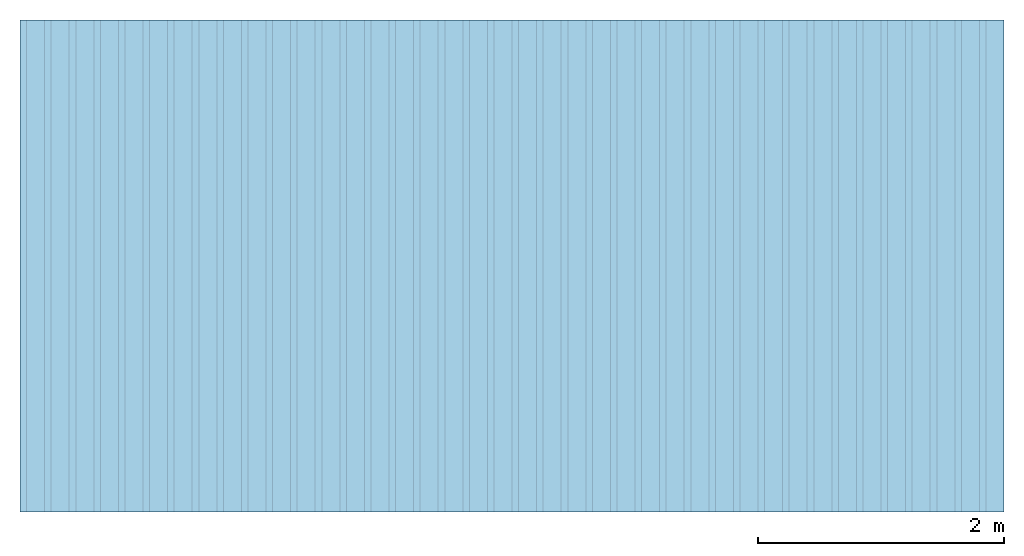
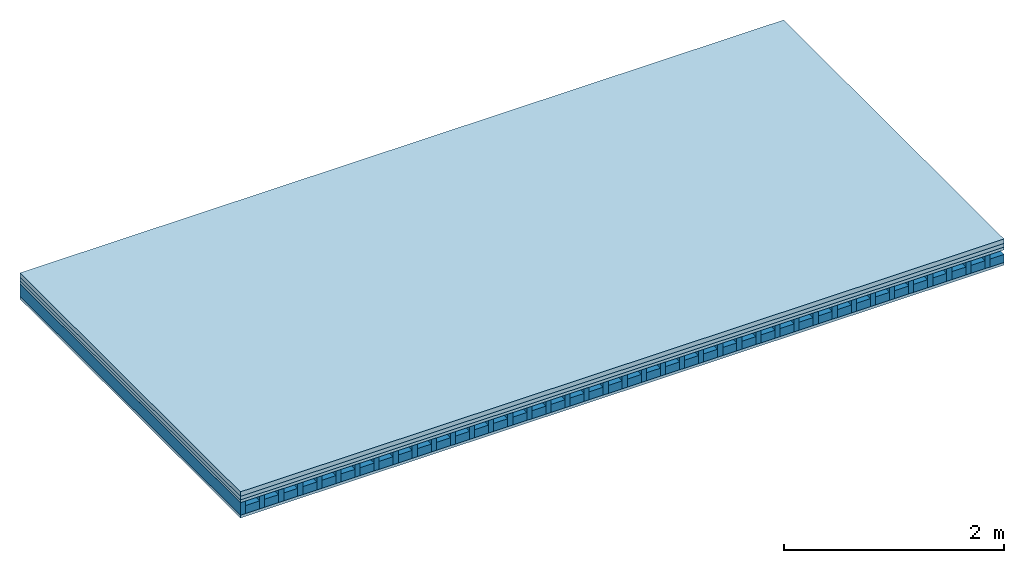
# One storey: 4 plates, 2 members, 1 element without a shape of its own.
"""IFC4 building model written with IfcOpenShell, lengths in metres."""

from ifc_helpers import new_model, si_unit, derived_unit, direction, frame, frame_2d, origin, origin_with_axes, place, context, project, spatial, rectangle, extrude, material, layer, layer_set, type_object, element, aggregate, save


model = new_model("IFC4")

# Units and contexts
plan_context = context("Plan", 3, precision=1e-05, world=origin(), true_north=direction((0.0, 1.0)))
model_context = context("Model", 3, precision=1e-05, world=origin(), true_north=direction((0.0, 1.0)))
ifc_project = project(units=[si_unit("LENGTHUNIT", "METRE"), derived_unit("SOUNDPRESSUREUNIT", [(si_unit("PRESSUREUNIT", "PASCAL", prefix="MICRO"), 0)]), si_unit("ENERGYUNIT", "JOULE", prefix="MEGA"), si_unit("MASSUNIT", "GRAM", prefix="KILO"), derived_unit("THERMALTRANSMITTANCEUNIT", [(si_unit("POWERUNIT", "WATT"), 1), (si_unit("AREAUNIT", "SQUARE_METRE"), -1), (si_unit("THERMODYNAMICTEMPERATUREUNIT", "KELVIN"), -1)]), derived_unit("AREADENSITYUNIT", [(si_unit("MASSUNIT", "GRAM", prefix="KILO"), 1), (si_unit("AREAUNIT", "SQUARE_METRE"), -1)]), derived_unit("USERDEFINED", [(si_unit("ENERGYUNIT", "JOULE", prefix="MEGA"), 1), (si_unit("AREAUNIT", "SQUARE_METRE"), -1)])], contexts=[plan_context, model_context])

# Site, building, storey
site = spatial("IfcSite", under=ifc_project)
building_placement = place(None, origin())
building = spatial("IfcBuilding", under=site, at=building_placement)
storey_placement = place(building_placement, origin())
storey = spatial("IfcBuildingStorey", under=building, at=storey_placement)

# Slab, members, plates
ifc_material_1 = material(Name="Cement screed", Category="04.006")
ifc_layer_1 = layer(ifc_material_1, 0.05, Name="On-material")
ifc_material_2 = material(Name="EP1, 40/35mm")
ifc_layer_2 = layer(ifc_material_2, 0.04, Name="Impact sound insulation")
ifc_material_3 = material(Name="box-element sheathing above")
ifc_layer_3 = layer(ifc_material_3, 0.031, Name="Sub-floor")
ifc_layer_4 = layer(None, 0.138, Name="Supporting structure")
ifc_material_4 = material(Name="box-element sheathing below")
ifc_layer_5 = layer(ifc_material_4, 0.031, Name="Lower layer 1")
ifc_layer_set = layer_set([ifc_layer_1, ifc_layer_2, ifc_layer_3, ifc_layer_4, ifc_layer_5])
slab_type = type_object("IfcSlabType", Name="A1465", PredefinedType="NOTDEFINED", material=ifc_layer_set)
slab_placement = place(None, frame((0.0, 0.0, 0.0), z_axis=(0.0, 0.0, -1.0), x_axis=(1.0, 0.0, 0.0)))
slab = element("IfcSlab", 1, at=slab_placement, inside=storey, type_object=slab_type, material=ifc_layer_set, Name="Slab #1")
ifc_material_5 = material(Name="box-element LKE 12")
member_1_placement = place(slab_placement, origin())
member_1 = element("IfcMember", 2, at=member_1_placement, material=ifc_material_5, Name="Supporting structure", context=plan_context, shape_type="SweptSolid", body=[
    extrude(rectangle(XDim=0.054, YDim=0.138, at=frame_2d((0.027, 0.069), x_axis=(1.0, 0.0))), frame((0.0, 4.0, 0.121), z_axis=(0.0, -1.0, 0.0), x_axis=(1.0, 0.0, 0.0)), (0.0, 0.0, 1.0), 4.0),
    extrude(rectangle(XDim=0.054, YDim=0.138, at=frame_2d((0.027, 0.069), x_axis=(1.0, 0.0))), frame((0.2, 4.0, 0.121), z_axis=(0.0, -1.0, 0.0), x_axis=(1.0, 0.0, 0.0)), (0.0, 0.0, 1.0), 4.0),
    extrude(rectangle(XDim=0.054, YDim=0.138, at=frame_2d((0.027, 0.069), x_axis=(1.0, 0.0))), frame((0.4, 4.0, 0.121), z_axis=(0.0, -1.0, 0.0), x_axis=(1.0, 0.0, 0.0)), (0.0, 0.0, 1.0), 4.0),
    extrude(rectangle(XDim=0.054, YDim=0.138, at=frame_2d((0.027, 0.069), x_axis=(1.0, 0.0))), frame((0.6, 4.0, 0.121), z_axis=(0.0, -1.0, 0.0), x_axis=(1.0, 0.0, 0.0)), (0.0, 0.0, 1.0), 4.0),
    extrude(rectangle(XDim=0.054, YDim=0.138, at=frame_2d((0.027, 0.069), x_axis=(1.0, 0.0))), frame((0.8, 4.0, 0.121), z_axis=(0.0, -1.0, 0.0), x_axis=(1.0, 0.0, 0.0)), (0.0, 0.0, 1.0), 4.0),
    extrude(rectangle(XDim=0.054, YDim=0.138, at=frame_2d((0.027, 0.069), x_axis=(1.0, 0.0))), frame((1.0, 4.0, 0.121), z_axis=(0.0, -1.0, 0.0), x_axis=(1.0, 0.0, 0.0)), (0.0, 0.0, 1.0), 4.0),
    extrude(rectangle(XDim=0.054, YDim=0.138, at=frame_2d((0.027, 0.069), x_axis=(1.0, 0.0))), frame((1.2, 4.0, 0.121), z_axis=(0.0, -1.0, 0.0), x_axis=(1.0, 0.0, 0.0)), (0.0, 0.0, 1.0), 4.0),
    extrude(rectangle(XDim=0.054, YDim=0.138, at=frame_2d((0.027, 0.069), x_axis=(1.0, 0.0))), frame((1.4, 4.0, 0.121), z_axis=(0.0, -1.0, 0.0), x_axis=(1.0, 0.0, 0.0)), (0.0, 0.0, 1.0), 4.0),
    extrude(rectangle(XDim=0.054, YDim=0.138, at=frame_2d((0.027, 0.069), x_axis=(1.0, 0.0))), frame((1.6, 4.0, 0.121), z_axis=(0.0, -1.0, 0.0), x_axis=(1.0, 0.0, 0.0)), (0.0, 0.0, 1.0), 4.0),
    extrude(rectangle(XDim=0.054, YDim=0.138, at=frame_2d((0.027, 0.069), x_axis=(1.0, 0.0))), frame((1.8, 4.0, 0.121), z_axis=(0.0, -1.0, 0.0), x_axis=(1.0, 0.0, 0.0)), (0.0, 0.0, 1.0), 4.0),
    extrude(rectangle(XDim=0.054, YDim=0.138, at=frame_2d((0.027, 0.069), x_axis=(1.0, 0.0))), frame((2.0, 4.0, 0.121), z_axis=(0.0, -1.0, 0.0), x_axis=(1.0, 0.0, 0.0)), (0.0, 0.0, 1.0), 4.0),
    extrude(rectangle(XDim=0.054, YDim=0.138, at=frame_2d((0.027, 0.069), x_axis=(1.0, 0.0))), frame((2.2, 4.0, 0.121), z_axis=(0.0, -1.0, 0.0), x_axis=(1.0, 0.0, 0.0)), (0.0, 0.0, 1.0), 4.0),
    extrude(rectangle(XDim=0.054, YDim=0.138, at=frame_2d((0.027, 0.069), x_axis=(1.0, 0.0))), frame((2.4, 4.0, 0.121), z_axis=(0.0, -1.0, 0.0), x_axis=(1.0, 0.0, 0.0)), (0.0, 0.0, 1.0), 4.0),
    extrude(rectangle(XDim=0.054, YDim=0.138, at=frame_2d((0.027, 0.069), x_axis=(1.0, 0.0))), frame((2.6, 4.0, 0.121), z_axis=(0.0, -1.0, 0.0), x_axis=(1.0, 0.0, 0.0)), (0.0, 0.0, 1.0), 4.0),
    extrude(rectangle(XDim=0.054, YDim=0.138, at=frame_2d((0.027, 0.069), x_axis=(1.0, 0.0))), frame((2.8, 4.0, 0.121), z_axis=(0.0, -1.0, 0.0), x_axis=(1.0, 0.0, 0.0)), (0.0, 0.0, 1.0), 4.0),
    extrude(rectangle(XDim=0.054, YDim=0.138, at=frame_2d((0.027, 0.069), x_axis=(1.0, 0.0))), frame((3.0, 4.0, 0.121), z_axis=(0.0, -1.0, 0.0), x_axis=(1.0, 0.0, 0.0)), (0.0, 0.0, 1.0), 4.0),
    extrude(rectangle(XDim=0.054, YDim=0.138, at=frame_2d((0.027, 0.069), x_axis=(1.0, 0.0))), frame((3.2, 4.0, 0.121), z_axis=(0.0, -1.0, 0.0), x_axis=(1.0, 0.0, 0.0)), (0.0, 0.0, 1.0), 4.0),
    extrude(rectangle(XDim=0.054, YDim=0.138, at=frame_2d((0.027, 0.069), x_axis=(1.0, 0.0))), frame((3.4, 4.0, 0.121), z_axis=(0.0, -1.0, 0.0), x_axis=(1.0, 0.0, 0.0)), (0.0, 0.0, 1.0), 4.0),
    extrude(rectangle(XDim=0.054, YDim=0.138, at=frame_2d((0.027, 0.069), x_axis=(1.0, 0.0))), frame((3.6, 4.0, 0.121), z_axis=(0.0, -1.0, 0.0), x_axis=(1.0, 0.0, 0.0)), (0.0, 0.0, 1.0), 4.0),
    extrude(rectangle(XDim=0.054, YDim=0.138, at=frame_2d((0.027, 0.069), x_axis=(1.0, 0.0))), frame((3.8, 4.0, 0.121), z_axis=(0.0, -1.0, 0.0), x_axis=(1.0, 0.0, 0.0)), (0.0, 0.0, 1.0), 4.0),
    extrude(rectangle(XDim=0.054, YDim=0.138, at=frame_2d((0.027, 0.069), x_axis=(1.0, 0.0))), frame((4.0, 4.0, 0.121), z_axis=(0.0, -1.0, 0.0), x_axis=(1.0, 0.0, 0.0)), (0.0, 0.0, 1.0), 4.0),
    extrude(rectangle(XDim=0.054, YDim=0.138, at=frame_2d((0.027, 0.069), x_axis=(1.0, 0.0))), frame((4.2, 4.0, 0.121), z_axis=(0.0, -1.0, 0.0), x_axis=(1.0, 0.0, 0.0)), (0.0, 0.0, 1.0), 4.0),
    extrude(rectangle(XDim=0.054, YDim=0.138, at=frame_2d((0.027, 0.069), x_axis=(1.0, 0.0))), frame((4.4, 4.0, 0.121), z_axis=(0.0, -1.0, 0.0), x_axis=(1.0, 0.0, 0.0)), (0.0, 0.0, 1.0), 4.0),
    extrude(rectangle(XDim=0.054, YDim=0.138, at=frame_2d((0.027, 0.069), x_axis=(1.0, 0.0))), frame((4.6, 4.0, 0.121), z_axis=(0.0, -1.0, 0.0), x_axis=(1.0, 0.0, 0.0)), (0.0, 0.0, 1.0), 4.0),
    extrude(rectangle(XDim=0.054, YDim=0.138, at=frame_2d((0.027, 0.069), x_axis=(1.0, 0.0))), frame((4.8, 4.0, 0.121), z_axis=(0.0, -1.0, 0.0), x_axis=(1.0, 0.0, 0.0)), (0.0, 0.0, 1.0), 4.0),
    extrude(rectangle(XDim=0.054, YDim=0.138, at=frame_2d((0.027, 0.069), x_axis=(1.0, 0.0))), frame((5.0, 4.0, 0.121), z_axis=(0.0, -1.0, 0.0), x_axis=(1.0, 0.0, 0.0)), (0.0, 0.0, 1.0), 4.0),
    extrude(rectangle(XDim=0.054, YDim=0.138, at=frame_2d((0.027, 0.069), x_axis=(1.0, 0.0))), frame((5.2, 4.0, 0.121), z_axis=(0.0, -1.0, 0.0), x_axis=(1.0, 0.0, 0.0)), (0.0, 0.0, 1.0), 4.0),
    extrude(rectangle(XDim=0.054, YDim=0.138, at=frame_2d((0.027, 0.069), x_axis=(1.0, 0.0))), frame((5.4, 4.0, 0.121), z_axis=(0.0, -1.0, 0.0), x_axis=(1.0, 0.0, 0.0)), (0.0, 0.0, 1.0), 4.0),
    extrude(rectangle(XDim=0.054, YDim=0.138, at=frame_2d((0.027, 0.069), x_axis=(1.0, 0.0))), frame((5.6, 4.0, 0.121), z_axis=(0.0, -1.0, 0.0), x_axis=(1.0, 0.0, 0.0)), (0.0, 0.0, 1.0), 4.0),
    extrude(rectangle(XDim=0.054, YDim=0.138, at=frame_2d((0.027, 0.069), x_axis=(1.0, 0.0))), frame((5.8, 4.0, 0.121), z_axis=(0.0, -1.0, 0.0), x_axis=(1.0, 0.0, 0.0)), (0.0, 0.0, 1.0), 4.0),
    extrude(rectangle(XDim=0.054, YDim=0.138, at=frame_2d((0.027, 0.069), x_axis=(1.0, 0.0))), frame((6.0, 4.0, 0.121), z_axis=(0.0, -1.0, 0.0), x_axis=(1.0, 0.0, 0.0)), (0.0, 0.0, 1.0), 4.0),
    extrude(rectangle(XDim=0.054, YDim=0.138, at=frame_2d((0.027, 0.069), x_axis=(1.0, 0.0))), frame((6.2, 4.0, 0.121), z_axis=(0.0, -1.0, 0.0), x_axis=(1.0, 0.0, 0.0)), (0.0, 0.0, 1.0), 4.0),
    extrude(rectangle(XDim=0.054, YDim=0.138, at=frame_2d((0.027, 0.069), x_axis=(1.0, 0.0))), frame((6.4, 4.0, 0.121), z_axis=(0.0, -1.0, 0.0), x_axis=(1.0, 0.0, 0.0)), (0.0, 0.0, 1.0), 4.0),
    extrude(rectangle(XDim=0.054, YDim=0.138, at=frame_2d((0.027, 0.069), x_axis=(1.0, 0.0))), frame((6.6, 4.0, 0.121), z_axis=(0.0, -1.0, 0.0), x_axis=(1.0, 0.0, 0.0)), (0.0, 0.0, 1.0), 4.0),
    extrude(rectangle(XDim=0.054, YDim=0.138, at=frame_2d((0.027, 0.069), x_axis=(1.0, 0.0))), frame((6.8, 4.0, 0.121), z_axis=(0.0, -1.0, 0.0), x_axis=(1.0, 0.0, 0.0)), (0.0, 0.0, 1.0), 4.0),
    extrude(rectangle(XDim=0.054, YDim=0.138, at=frame_2d((0.027, 0.069), x_axis=(1.0, 0.0))), frame((7.0, 4.0, 0.121), z_axis=(0.0, -1.0, 0.0), x_axis=(1.0, 0.0, 0.0)), (0.0, 0.0, 1.0), 4.0),
    extrude(rectangle(XDim=0.054, YDim=0.138, at=frame_2d((0.027, 0.069), x_axis=(1.0, 0.0))), frame((7.2, 4.0, 0.121), z_axis=(0.0, -1.0, 0.0), x_axis=(1.0, 0.0, 0.0)), (0.0, 0.0, 1.0), 4.0),
    extrude(rectangle(XDim=0.054, YDim=0.138, at=frame_2d((0.027, 0.069), x_axis=(1.0, 0.0))), frame((7.4, 4.0, 0.121), z_axis=(0.0, -1.0, 0.0), x_axis=(1.0, 0.0, 0.0)), (0.0, 0.0, 1.0), 4.0),
    extrude(rectangle(XDim=0.054, YDim=0.138, at=frame_2d((0.027, 0.069), x_axis=(1.0, 0.0))), frame((7.6, 4.0, 0.121), z_axis=(0.0, -1.0, 0.0), x_axis=(1.0, 0.0, 0.0)), (0.0, 0.0, 1.0), 4.0),
    extrude(rectangle(XDim=0.054, YDim=0.138, at=frame_2d((0.027, 0.069), x_axis=(1.0, 0.0))), frame((7.8, 4.0, 0.121), z_axis=(0.0, -1.0, 0.0), x_axis=(1.0, 0.0, 0.0)), (0.0, 0.0, 1.0), 4.0),
])
ifc_material_6 = material(Name="Damper and limestone LKE 12")
member_2_placement = place(slab_placement, origin())
member_2 = element("IfcMember", 3, at=member_2_placement, material=ifc_material_6, Name="in supporting structure", context=plan_context, shape_type="SweptSolid", body=[
    extrude(rectangle(XDim=0.146, YDim=0.088, at=frame_2d((0.073, 0.044), x_axis=(1.0, 0.0))), frame((0.054, 4.0, 0.171), z_axis=(0.0, -1.0, 0.0), x_axis=(1.0, 0.0, 0.0)), (0.0, 0.0, 1.0), 4.0),
    extrude(rectangle(XDim=0.146, YDim=0.088, at=frame_2d((0.073, 0.044), x_axis=(1.0, 0.0))), frame((0.254, 4.0, 0.171), z_axis=(0.0, -1.0, 0.0), x_axis=(1.0, 0.0, 0.0)), (0.0, 0.0, 1.0), 4.0),
    extrude(rectangle(XDim=0.146, YDim=0.088, at=frame_2d((0.073, 0.044), x_axis=(1.0, 0.0))), frame((0.454, 4.0, 0.171), z_axis=(0.0, -1.0, 0.0), x_axis=(1.0, 0.0, 0.0)), (0.0, 0.0, 1.0), 4.0),
    extrude(rectangle(XDim=0.146, YDim=0.088, at=frame_2d((0.073, 0.044), x_axis=(1.0, 0.0))), frame((0.654, 4.0, 0.171), z_axis=(0.0, -1.0, 0.0), x_axis=(1.0, 0.0, 0.0)), (0.0, 0.0, 1.0), 4.0),
    extrude(rectangle(XDim=0.146, YDim=0.088, at=frame_2d((0.073, 0.044), x_axis=(1.0, 0.0))), frame((0.854, 4.0, 0.171), z_axis=(0.0, -1.0, 0.0), x_axis=(1.0, 0.0, 0.0)), (0.0, 0.0, 1.0), 4.0),
    extrude(rectangle(XDim=0.146, YDim=0.088, at=frame_2d((0.073, 0.044), x_axis=(1.0, 0.0))), frame((1.054, 4.0, 0.171), z_axis=(0.0, -1.0, 0.0), x_axis=(1.0, 0.0, 0.0)), (0.0, 0.0, 1.0), 4.0),
    extrude(rectangle(XDim=0.146, YDim=0.088, at=frame_2d((0.073, 0.044), x_axis=(1.0, 0.0))), frame((1.254, 4.0, 0.171), z_axis=(0.0, -1.0, 0.0), x_axis=(1.0, 0.0, 0.0)), (0.0, 0.0, 1.0), 4.0),
    extrude(rectangle(XDim=0.146, YDim=0.088, at=frame_2d((0.073, 0.044), x_axis=(1.0, 0.0))), frame((1.454, 4.0, 0.171), z_axis=(0.0, -1.0, 0.0), x_axis=(1.0, 0.0, 0.0)), (0.0, 0.0, 1.0), 4.0),
    extrude(rectangle(XDim=0.146, YDim=0.088, at=frame_2d((0.073, 0.044), x_axis=(1.0, 0.0))), frame((1.654, 4.0, 0.171), z_axis=(0.0, -1.0, 0.0), x_axis=(1.0, 0.0, 0.0)), (0.0, 0.0, 1.0), 4.0),
    extrude(rectangle(XDim=0.146, YDim=0.088, at=frame_2d((0.073, 0.044), x_axis=(1.0, 0.0))), frame((1.854, 4.0, 0.171), z_axis=(0.0, -1.0, 0.0), x_axis=(1.0, 0.0, 0.0)), (0.0, 0.0, 1.0), 4.0),
    extrude(rectangle(XDim=0.146, YDim=0.088, at=frame_2d((0.073, 0.044), x_axis=(1.0, 0.0))), frame((2.054, 4.0, 0.171), z_axis=(0.0, -1.0, 0.0), x_axis=(1.0, 0.0, 0.0)), (0.0, 0.0, 1.0), 4.0),
    extrude(rectangle(XDim=0.146, YDim=0.088, at=frame_2d((0.073, 0.044), x_axis=(1.0, 0.0))), frame((2.254, 4.0, 0.171), z_axis=(0.0, -1.0, 0.0), x_axis=(1.0, 0.0, 0.0)), (0.0, 0.0, 1.0), 4.0),
    extrude(rectangle(XDim=0.146, YDim=0.088, at=frame_2d((0.073, 0.044), x_axis=(1.0, 0.0))), frame((2.454, 4.0, 0.171), z_axis=(0.0, -1.0, 0.0), x_axis=(1.0, 0.0, 0.0)), (0.0, 0.0, 1.0), 4.0),
    extrude(rectangle(XDim=0.146, YDim=0.088, at=frame_2d((0.073, 0.044), x_axis=(1.0, 0.0))), frame((2.654, 4.0, 0.171), z_axis=(0.0, -1.0, 0.0), x_axis=(1.0, 0.0, 0.0)), (0.0, 0.0, 1.0), 4.0),
    extrude(rectangle(XDim=0.146, YDim=0.088, at=frame_2d((0.073, 0.044), x_axis=(1.0, 0.0))), frame((2.854, 4.0, 0.171), z_axis=(0.0, -1.0, 0.0), x_axis=(1.0, 0.0, 0.0)), (0.0, 0.0, 1.0), 4.0),
    extrude(rectangle(XDim=0.146, YDim=0.088, at=frame_2d((0.073, 0.044), x_axis=(1.0, 0.0))), frame((3.054, 4.0, 0.171), z_axis=(0.0, -1.0, 0.0), x_axis=(1.0, 0.0, 0.0)), (0.0, 0.0, 1.0), 4.0),
    extrude(rectangle(XDim=0.146, YDim=0.088, at=frame_2d((0.073, 0.044), x_axis=(1.0, 0.0))), frame((3.254, 4.0, 0.171), z_axis=(0.0, -1.0, 0.0), x_axis=(1.0, 0.0, 0.0)), (0.0, 0.0, 1.0), 4.0),
    extrude(rectangle(XDim=0.146, YDim=0.088, at=frame_2d((0.073, 0.044), x_axis=(1.0, 0.0))), frame((3.454, 4.0, 0.171), z_axis=(0.0, -1.0, 0.0), x_axis=(1.0, 0.0, 0.0)), (0.0, 0.0, 1.0), 4.0),
    extrude(rectangle(XDim=0.146, YDim=0.088, at=frame_2d((0.073, 0.044), x_axis=(1.0, 0.0))), frame((3.654, 4.0, 0.171), z_axis=(0.0, -1.0, 0.0), x_axis=(1.0, 0.0, 0.0)), (0.0, 0.0, 1.0), 4.0),
    extrude(rectangle(XDim=0.146, YDim=0.088, at=frame_2d((0.073, 0.044), x_axis=(1.0, 0.0))), frame((3.854, 4.0, 0.171), z_axis=(0.0, -1.0, 0.0), x_axis=(1.0, 0.0, 0.0)), (0.0, 0.0, 1.0), 4.0),
    extrude(rectangle(XDim=0.146, YDim=0.088, at=frame_2d((0.073, 0.044), x_axis=(1.0, 0.0))), frame((4.054, 4.0, 0.171), z_axis=(0.0, -1.0, 0.0), x_axis=(1.0, 0.0, 0.0)), (0.0, 0.0, 1.0), 4.0),
    extrude(rectangle(XDim=0.146, YDim=0.088, at=frame_2d((0.073, 0.044), x_axis=(1.0, 0.0))), frame((4.254, 4.0, 0.171), z_axis=(0.0, -1.0, 0.0), x_axis=(1.0, 0.0, 0.0)), (0.0, 0.0, 1.0), 4.0),
    extrude(rectangle(XDim=0.146, YDim=0.088, at=frame_2d((0.073, 0.044), x_axis=(1.0, 0.0))), frame((4.454, 4.0, 0.171), z_axis=(0.0, -1.0, 0.0), x_axis=(1.0, 0.0, 0.0)), (0.0, 0.0, 1.0), 4.0),
    extrude(rectangle(XDim=0.146, YDim=0.088, at=frame_2d((0.073, 0.044), x_axis=(1.0, 0.0))), frame((4.654, 4.0, 0.171), z_axis=(0.0, -1.0, 0.0), x_axis=(1.0, 0.0, 0.0)), (0.0, 0.0, 1.0), 4.0),
    extrude(rectangle(XDim=0.146, YDim=0.088, at=frame_2d((0.073, 0.044), x_axis=(1.0, 0.0))), frame((4.854, 4.0, 0.171), z_axis=(0.0, -1.0, 0.0), x_axis=(1.0, 0.0, 0.0)), (0.0, 0.0, 1.0), 4.0),
    extrude(rectangle(XDim=0.146, YDim=0.088, at=frame_2d((0.073, 0.044), x_axis=(1.0, 0.0))), frame((5.054, 4.0, 0.171), z_axis=(0.0, -1.0, 0.0), x_axis=(1.0, 0.0, 0.0)), (0.0, 0.0, 1.0), 4.0),
    extrude(rectangle(XDim=0.146, YDim=0.088, at=frame_2d((0.073, 0.044), x_axis=(1.0, 0.0))), frame((5.254, 4.0, 0.171), z_axis=(0.0, -1.0, 0.0), x_axis=(1.0, 0.0, 0.0)), (0.0, 0.0, 1.0), 4.0),
    extrude(rectangle(XDim=0.146, YDim=0.088, at=frame_2d((0.073, 0.044), x_axis=(1.0, 0.0))), frame((5.454, 4.0, 0.171), z_axis=(0.0, -1.0, 0.0), x_axis=(1.0, 0.0, 0.0)), (0.0, 0.0, 1.0), 4.0),
    extrude(rectangle(XDim=0.146, YDim=0.088, at=frame_2d((0.073, 0.044), x_axis=(1.0, 0.0))), frame((5.654, 4.0, 0.171), z_axis=(0.0, -1.0, 0.0), x_axis=(1.0, 0.0, 0.0)), (0.0, 0.0, 1.0), 4.0),
    extrude(rectangle(XDim=0.146, YDim=0.088, at=frame_2d((0.073, 0.044), x_axis=(1.0, 0.0))), frame((5.854, 4.0, 0.171), z_axis=(0.0, -1.0, 0.0), x_axis=(1.0, 0.0, 0.0)), (0.0, 0.0, 1.0), 4.0),
    extrude(rectangle(XDim=0.146, YDim=0.088, at=frame_2d((0.073, 0.044), x_axis=(1.0, 0.0))), frame((6.054, 4.0, 0.171), z_axis=(0.0, -1.0, 0.0), x_axis=(1.0, 0.0, 0.0)), (0.0, 0.0, 1.0), 4.0),
    extrude(rectangle(XDim=0.146, YDim=0.088, at=frame_2d((0.073, 0.044), x_axis=(1.0, 0.0))), frame((6.254, 4.0, 0.171), z_axis=(0.0, -1.0, 0.0), x_axis=(1.0, 0.0, 0.0)), (0.0, 0.0, 1.0), 4.0),
    extrude(rectangle(XDim=0.146, YDim=0.088, at=frame_2d((0.073, 0.044), x_axis=(1.0, 0.0))), frame((6.454, 4.0, 0.171), z_axis=(0.0, -1.0, 0.0), x_axis=(1.0, 0.0, 0.0)), (0.0, 0.0, 1.0), 4.0),
    extrude(rectangle(XDim=0.146, YDim=0.088, at=frame_2d((0.073, 0.044), x_axis=(1.0, 0.0))), frame((6.654, 4.0, 0.171), z_axis=(0.0, -1.0, 0.0), x_axis=(1.0, 0.0, 0.0)), (0.0, 0.0, 1.0), 4.0),
    extrude(rectangle(XDim=0.146, YDim=0.088, at=frame_2d((0.073, 0.044), x_axis=(1.0, 0.0))), frame((6.854, 4.0, 0.171), z_axis=(0.0, -1.0, 0.0), x_axis=(1.0, 0.0, 0.0)), (0.0, 0.0, 1.0), 4.0),
    extrude(rectangle(XDim=0.146, YDim=0.088, at=frame_2d((0.073, 0.044), x_axis=(1.0, 0.0))), frame((7.054, 4.0, 0.171), z_axis=(0.0, -1.0, 0.0), x_axis=(1.0, 0.0, 0.0)), (0.0, 0.0, 1.0), 4.0),
    extrude(rectangle(XDim=0.146, YDim=0.088, at=frame_2d((0.073, 0.044), x_axis=(1.0, 0.0))), frame((7.254, 4.0, 0.171), z_axis=(0.0, -1.0, 0.0), x_axis=(1.0, 0.0, 0.0)), (0.0, 0.0, 1.0), 4.0),
    extrude(rectangle(XDim=0.146, YDim=0.088, at=frame_2d((0.073, 0.044), x_axis=(1.0, 0.0))), frame((7.454, 4.0, 0.171), z_axis=(0.0, -1.0, 0.0), x_axis=(1.0, 0.0, 0.0)), (0.0, 0.0, 1.0), 4.0),
    extrude(rectangle(XDim=0.146, YDim=0.088, at=frame_2d((0.073, 0.044), x_axis=(1.0, 0.0))), frame((7.654, 4.0, 0.171), z_axis=(0.0, -1.0, 0.0), x_axis=(1.0, 0.0, 0.0)), (0.0, 0.0, 1.0), 4.0),
    extrude(rectangle(XDim=0.146, YDim=0.088, at=frame_2d((0.073, 0.044), x_axis=(1.0, 0.0))), frame((7.854, 4.0, 0.171), z_axis=(0.0, -1.0, 0.0), x_axis=(1.0, 0.0, 0.0)), (0.0, 0.0, 1.0), 4.0),
])
plate_1_placement = place(slab_placement, origin())
plate_1 = element("IfcPlate", 4, at=plate_1_placement, material=ifc_material_1, Name="On-material", context=plan_context, shape_type="SweptSolid", body=[
    extrude(rectangle(XDim=8.0, YDim=4.0, at=frame_2d((4.0, 2.0), x_axis=(1.0, 0.0))), origin_with_axes(), (0.0, 0.0, 1.0), 0.05),
])
plate_2_placement = place(slab_placement, origin())
plate_2 = element("IfcPlate", 5, at=plate_2_placement, material=ifc_material_2, Name="Impact sound insulation", context=plan_context, shape_type="SweptSolid", body=[
    extrude(rectangle(XDim=8.0, YDim=4.0, at=frame_2d((4.0, 2.0), x_axis=(1.0, 0.0))), frame((0.0, 0.0, 0.05), z_axis=(0.0, 0.0, 1.0), x_axis=(1.0, 0.0, 0.0)), (0.0, 0.0, 1.0), 0.04),
])
plate_3_placement = place(slab_placement, origin())
plate_3 = element("IfcPlate", 6, at=plate_3_placement, material=ifc_material_3, Name="Sub-floor", context=plan_context, shape_type="SweptSolid", body=[
    extrude(rectangle(XDim=8.0, YDim=4.0, at=frame_2d((4.0, 2.0), x_axis=(1.0, 0.0))), frame((0.0, 0.0, 0.09), z_axis=(0.0, 0.0, 1.0), x_axis=(1.0, 0.0, 0.0)), (0.0, 0.0, 1.0), 0.031),
])
plate_4_placement = place(slab_placement, origin())
plate_4 = element("IfcPlate", 7, at=plate_4_placement, material=ifc_material_4, Name="Lower layer 1", context=plan_context, shape_type="SweptSolid", body=[
    extrude(rectangle(XDim=8.0, YDim=4.0, at=frame_2d((4.0, 2.0), x_axis=(1.0, 0.0))), frame((0.0, 0.0, 0.259), z_axis=(0.0, 0.0, 1.0), x_axis=(1.0, 0.0, 0.0)), (0.0, 0.0, 1.0), 0.031),
])
aggregate(slab, [plate_1, plate_2, plate_3, member_1, member_2, plate_4])

save(model, "model.ifc")
